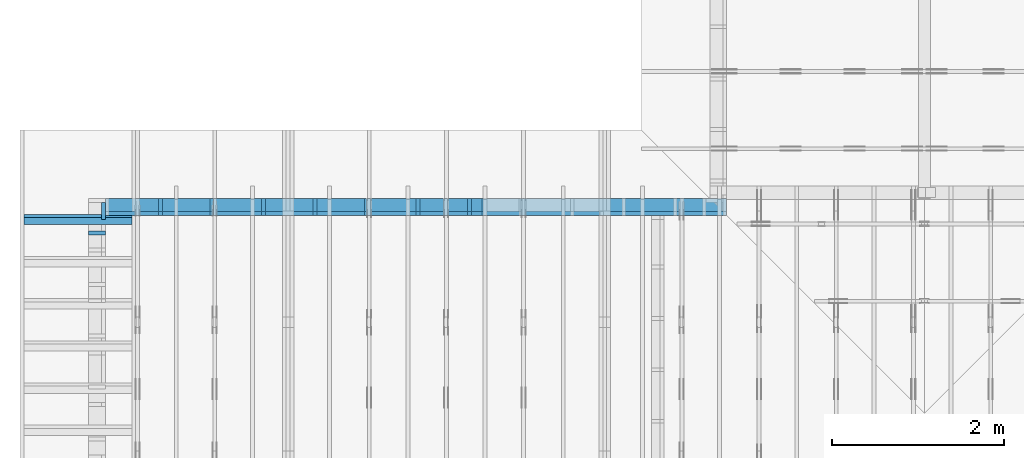
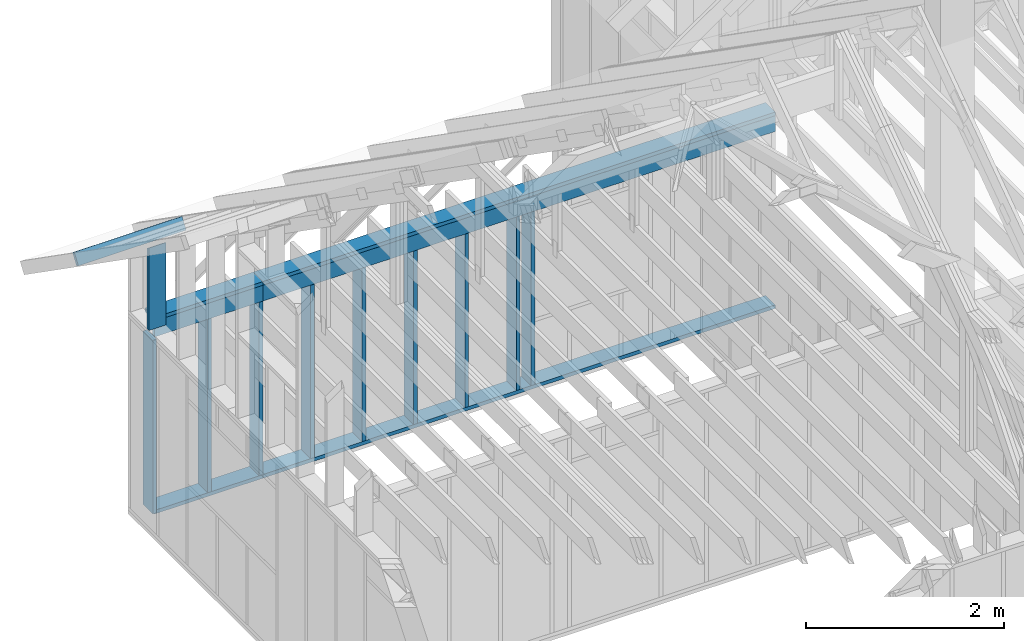
# One storey, part 29 of 70: 17 members, 4 elements without a shape of their own.
"""IFC2X3 building model written with IfcOpenShell, lengths in millimetres."""

from ifc_helpers import new_model, si_unit, frame, origin, origin_with_axes, origin_2d, place, context, project, spatial, faceted_brep, element, aggregate, save


model = new_model("IFC2X3")

# Units and contexts
model_context = context("Model", 3, precision=1e-05, world=origin())
plan_context = context("Plan", 2, precision=1e-05, world=origin_2d())
ifc_project = project(units=[si_unit("LENGTHUNIT", "METRE", prefix="MILLI"), si_unit("AREAUNIT", "SQUARE_METRE"), si_unit("VOLUMEUNIT", "CUBIC_METRE"), si_unit("SOLIDANGLEUNIT", "STERADIAN"), si_unit("PLANEANGLEUNIT", "RADIAN"), si_unit("MASSUNIT", "GRAM"), si_unit("TIMEUNIT", "SECOND"), si_unit("THERMODYNAMICTEMPERATUREUNIT", "DEGREE_CELSIUS"), si_unit("LUMINOUSINTENSITYUNIT", "LUMEN")], contexts=[model_context, plan_context])

# Site, building, storey
site_placement = place(None, origin_with_axes())
site = spatial("IfcSite", under=ifc_project, at=site_placement, CompositionType="ELEMENT")
building_placement = place(site_placement, origin_with_axes())
building = spatial("IfcBuilding", under=site, at=building_placement, Name="Layout 1", CompositionType="ELEMENT")
storey_placement = place(building_placement, origin_with_axes())
storey = spatial("IfcBuildingStorey", under=building, at=storey_placement, Name="Storey 1", CompositionType="ELEMENT", Elevation=0.0)

# Assembly, members
assembly_1_placement = place(storey_placement, frame((6999.999999999999, 8000.0, -2470.0), z_axis=(1.2246063538223773e-16, 1.0, 6.123031769111886e-17), x_axis=(-1.0, 1.2246063538223773e-16, 0.0)))
assembly_1 = element("IfcElementAssembly", 1, at=assembly_1_placement, inside=storey, Name="VE2", AssemblyPlace="FACTORY", PredefinedType="NOTDEFINED")
member_1_placement = place(assembly_1_placement, frame((-194.99999999999986, 2425.0, -195.0), z_axis=(0.0, 0.0, 1.0), x_axis=(1.0, 0.0, 0.0)))
member_1 = element("IfcMember", 2, at=member_1_placement, Name="P1", context=model_context, shape_type="Brep", body=[
    faceted_brep([(5980.0, 45.0, 195.0), (0.0, 45.0, 195.0), (0.0, 0.0, 195.0), (5980.0, 0.0, 195.0), (0.0, 45.0, 0.0), (5980.0, 45.0, 7.323145995857816e-13), (5980.0, 0.0, 7.323145995857816e-13), (0.0, 0.0, 0.0), (0.0, 0.0, 0.0), (1.1939911949768178e-14, -1.462169203776584e-30, 195.0), (1.7450640541968876e-14, 45.0, 195.0), (5.510728592200698e-15, 45.0, -3.3742366240998092e-31), (5980.0, -1.0984718993786724e-12, 6.725978337372286e-29), (5980.0, -1.0865319874289042e-12, 195.0), (2.193253805664876e-30, 1.1939911949768178e-14, 195.0), (0.0, 0.0, 0.0), (5980.0, 45.0, 0.0), (5980.0, 45.0, 195.0), (5980.0, 0.0, 195.0), (5980.0, 0.0, 0.0), (0.0, 45.0, 0.0), (-7.31084601888292e-31, 44.999999999999986, 195.0), (5980.0, 44.99999999999962, 195.0), (5980.0, 44.99999999999963, -2.2482535798798836e-29)], [[[0, 1, 2, 3]], [[4, 5, 6, 7]], [[8, 9, 10, 11]], [[12, 13, 14, 15]], [[16, 17, 18, 19]], [[20, 21, 22, 23]]]),
])
member_2_placement = place(assembly_1_placement, frame((5785.0, 2425.0, -195.0), z_axis=(0.0, 0.0, 1.0), x_axis=(1.0, 0.0, 0.0)))
member_2 = element("IfcMember", 3, at=member_2_placement, Name="P12", context=model_context, shape_type="Brep", body=[
    faceted_brep([(1263.5533905932753, 45.0, 195.0), (0.0, 45.0, 195.0), (0.0, 0.0, 195.0), (1263.5533905932753, 0.0, 195.0), (0.0, 45.0, 0.0), (1263.5533905932753, 45.0, 1.5473555105143328e-13), (1263.5533905932753, 0.0, 1.5473555105143328e-13), (0.0, 0.0, 0.0), (0.0, 0.0, 0.0), (1.1939911949768178e-14, -1.462169203776584e-30, 195.0), (1.7450640541968876e-14, 45.0, 195.0), (5.510728592200698e-15, 45.0, -3.3742366240998092e-31), (1263.5533905932753, -2.3210332657714993e-13, 1.4211760423484402e-29), (1263.5533905932753, -2.2016341462738176e-13, 195.0), (2.193253805664876e-30, 1.1939911949768178e-14, 195.0), (0.0, 0.0, 0.0), (1263.5533905932753, 45.0, 0.0), (1263.5533905932753, 45.0, 195.0), (1263.5533905932753, 0.0, 195.0), (1263.5533905932753, 0.0, 0.0), (0.0, 45.0, 0.0), (-7.31084601888292e-31, 44.999999999999986, 195.0), (1263.5533905932753, 44.99999999999991, 195.0), (1263.5533905932753, 44.99999999999992, -4.733165431326071e-30)], [[[0, 1, 2, 3]], [[4, 5, 6, 7]], [[8, 9, 10, 11]], [[12, 13, 14, 15]], [[16, 17, 18, 19]], [[20, 21, 22, 23]]]),
])
member_3_placement = place(assembly_1_placement, frame((7048.553390593275, 90.0, -195.0), z_axis=(0.0, 0.0, 1.0), x_axis=(-1.0, 1.2246063538223773e-16, 0.0)))
member_3 = element("IfcMember", 4, at=member_3_placement, Name="P12", context=model_context, shape_type="Brep", body=[
    faceted_brep([(1263.5533905932753, 45.000000000000156, 195.0), (0.0, 45.000000000000156, 195.0), (0.0, 0.0, 195.0), (1263.5533905932753, 0.0, 195.0), (0.0, 45.000000000000156, 0.0), (1263.5533905932753, 45.000000000000156, 1.5473555105143328e-13), (1263.5533905932753, 0.0, 1.5473555105143328e-13), (0.0, 0.0, 0.0), (0.0, 0.0, 0.0), (1.1939911949768178e-14, -1.462169203776584e-30, 195.0), (1.7450640541968876e-14, 45.00000000000001, 195.0), (5.5107285922006985e-15, 45.00000000000001, -3.3742366240998097e-31), (1263.5533905932753, -2.3210332657714993e-13, 2.3783247061100087e-29), (1263.5533905932753, -2.2016341462738176e-13, 195.0), (2.193253805664876e-30, 1.1939911949768178e-14, 195.0), (0.0, 0.0, 0.0), (1263.5533905932753, 45.000000000000156, 0.0), (1263.5533905932753, 45.000000000000156, 195.0), (1263.5533905932753, 1.5631940186722204e-13, 195.0), (1263.5533905932753, 1.5631940186722204e-13, 0.0), (0.0, 45.00000000000001, 0.0), (1.5777218104420236e-30, 44.99999999999999, 195.0), (1263.5533905932753, 45.0000000000002, 195.0), (1263.5533905932753, 45.00000000000021, 3.549874073494553e-30)], [[[0, 1, 2, 3]], [[4, 5, 6, 7]], [[8, 9, 10, 11]], [[12, 13, 14, 15]], [[16, 17, 18, 19]], [[20, 21, 22, 23]]]),
])
member_4_placement = place(assembly_1_placement, frame((5785.0, 90.0, -195.0), z_axis=(0.0, 0.0, 1.0), x_axis=(-1.0, 1.2246063538223773e-16, 0.0)))
member_4 = element("IfcMember", 5, at=member_4_placement, Name="P1", context=model_context, shape_type="Brep", body=[
    faceted_brep([(5980.0, 45.00000000000073, 195.0), (0.0, 45.00000000000073, 195.0), (0.0, 0.0, 195.0), (5980.0, 0.0, 195.0), (0.0, 45.00000000000073, 0.0), (5980.0, 45.00000000000073, 7.323145995857816e-13), (5980.0, 0.0, 7.323145995857816e-13), (0.0, 0.0, 0.0), (0.0, 0.0, 0.0), (1.1939911949768178e-14, -1.462169203776584e-30, 195.0), (1.7450640541968876e-14, 45.0, 195.0), (5.510728592200698e-15, 45.0, -3.3742366240998092e-31), (5980.0, -1.0984718993786724e-12, 1.1250681111517883e-28), (5980.0, -1.0865319874289042e-12, 195.0), (2.193253805664876e-30, 1.1939911949768178e-14, 195.0), (0.0, 0.0, 0.0), (5980.0, 45.00000000000073, 0.0), (5980.0, 45.00000000000073, 195.0), (5980.0, 7.389644451905042e-13, 195.0), (5980.0, 7.389644451905042e-13, 0.0), (0.0, 45.0, 0.0), (1.5777218104420236e-30, 44.999999999999986, 195.0), (5980.0, 45.00000000000095, 195.0), (5980.0, 45.00000000000096, 1.3805065841367707e-29)], [[[0, 1, 2, 3]], [[4, 5, 6, 7]], [[8, 9, 10, 11]], [[12, 13, 14, 15]], [[16, 17, 18, 19]], [[20, 21, 22, 23]]]),
])
member_5_placement = place(assembly_1_placement, frame((-194.99999999999986, 2229.9999999981374, -195.0), z_axis=(0.0, 0.0, 1.0), x_axis=(1.0, 0.0, 0.0)))
member_5 = element("IfcMember", 6, at=member_5_placement, Name="S34", context=model_context, shape_type="Brep", body=[
    faceted_brep([(5980.0, 195.00000000186265, 45.0), (0.0, 195.00000000186265, 45.0), (0.0, 0.0, 45.0), (5980.0, 0.0, 45.0), (0.0, 195.00000000186265, 0.0), (5980.0, 195.00000000186265, 7.323145995857816e-13), (5980.0, 0.0, 7.323145995857816e-13), (0.0, 0.0, 0.0), (0.0, 0.0, 0.0), (2.755364296100349e-15, -3.3742366240998092e-31, 45.0), (2.6635188195864806e-14, 195.00000000186265, 45.0), (2.3879823899764457e-14, 195.00000000186265, -1.4621692037905507e-30), (5980.0, 1.86317026748279e-09, -3.2153157385149134e-29), (5980.0, 1.8631730228470863e-09, 45.0), (-8.584804067855881e-28, 2.755364296100349e-15, 45.0), (0.0, 0.0, 0.0), (5980.0, 195.00000000186265, 0.0), (5980.0, 195.00000000186265, 45.0), (5980.0, 1.862645149230957e-09, 45.0), (5980.0, 1.862645149230957e-09, 0.0), (0.0, 195.00000000186265, 0.0), (-1.6871183120499046e-31, 195.00000000186265, 45.0), (5980.0, 195.00000000186228, 45.0), (5980.0, 195.00000000186228, -2.208810534618833e-29)], [[[0, 1, 2, 3]], [[4, 5, 6, 7]], [[8, 9, 10, 11]], [[12, 13, 14, 15]], [[16, 17, 18, 19]], [[20, 21, 22, 23]]]),
])
member_6_placement = place(assembly_1_placement, frame((5785.0, 2230.0, -195.0), z_axis=(0.0, 0.0, 1.0), x_axis=(1.0, 0.0, 0.0)))
member_6 = element("IfcMember", 7, at=member_6_placement, Name="L9", context=model_context, shape_type="Brep", body=[
    faceted_brep([(1263.5533905932753, 195.0, 45.0), (0.0, 195.0, 45.0), (0.0, 0.0, 45.0), (1263.5533905932753, 0.0, 45.0), (0.0, 195.0, 0.0), (1263.5533905932753, 195.0, 1.5473555105143328e-13), (1263.5533905932753, 0.0, 1.5473555105143328e-13), (0.0, 0.0, 0.0), (0.0, 0.0, 0.0), (2.755364296100349e-15, -3.3742366240998092e-31, 45.0), (2.6635188195636705e-14, 195.0, 45.0), (2.3879823899536357e-14, 195.0, -1.462169203776584e-30), (1263.5533905932753, -2.3210332657714993e-13, 1.4211760423484402e-29), (1263.5533905932753, -2.293479622810496e-13, 45.0), (5.061354936149714e-31, 2.755364296100349e-15, 45.0), (0.0, 0.0, 0.0), (1263.5533905932753, 195.0, 0.0), (1263.5533905932753, 195.0, 45.0), (1263.5533905932753, 0.0, 45.0), (1263.5533905932753, 0.0, 0.0), (0.0, 195.0, 0.0), (-1.6871183120499046e-31, 195.0, 45.0), (1263.5533905932753, 194.99999999999991, 45.0), (1263.5533905932753, 194.99999999999991, -4.733165431326071e-30)], [[[0, 1, 2, 3]], [[4, 5, 6, 7]], [[8, 9, 10, 11]], [[12, 13, 14, 15]], [[16, 17, 18, 19]], [[20, 21, 22, 23]]]),
])
member_7_placement = place(assembly_1_placement, frame((5182.500000001819, 2425.0, -195.00000000000003), z_axis=(0.0, 0.0, 1.0), x_axis=(-1.836909530733566e-16, -1.0, 0.0)))
member_7 = element("IfcMember", 8, at=member_7_placement, Name="S11", context=model_context, shape_type="Brep", body=[
    faceted_brep([(0.0, 45.00000000001455, 45.00000000000003), (195.00000000186265, 45.00000000001455, 45.00000000000005), (195.00000000186265, 0.0, 45.00000000000005), (0.0, 0.0, 45.00000000000003), (195.00000000186265, -2.1311460639909362e-46, 2.842170943040401e-14), (195.00000000186265, -3.3742366240998114e-31, 45.00000000000003), (195.00000000186265, 45.00000000001364, 45.00000000000003), (195.00000000186265, 45.00000000001364, 2.842170943040401e-14), (2.7553642961003504e-15, -3.3742366240998114e-31, 45.00000000000003), (1.1939911949768181e-14, -1.4621692037765844e-30, 195.00000000000006), (1.7450640541970662e-14, 45.00000000001455, 195.00000000000006), (8.26609288830283e-15, 45.00000000001455, 45.00000000000003), (2335.0, -4.2891837542628763e-13, 2.842170943040403e-14), (2335.0, -4.1697846347651946e-13, 195.00000000000003), (2.1932538056648764e-30, 1.193991194976818e-14, 195.00000000000003), (5.061354936149717e-31, 2.7553642961003504e-15, 45.00000000000003), (195.00000000186265, -3.306437155354634e-14, 45.00000000000003), (195.00000000186265, -3.5819735849646686e-14, 2.842170943040401e-14), (-1.6871183120499057e-31, 45.00000000001364, 45.00000000000003), (-7.310846018882921e-31, 45.00000000001363, 195.00000000000003), (2335.0, 45.000000000013486, 195.00000000000003), (2335.0, 45.0000000000135, 2.8421709430403998e-14), (195.00000000186265, 45.00000000001363, 2.842170943040401e-14), (195.00000000186265, 45.00000000001363, 45.00000000000003), (2335.0, 45.0, 0.0), (2335.0, 45.0, 195.00000000000003), (2335.0, 0.0, 195.00000000000003), (2335.0, 0.0, 0.0), (2335.0, 45.0, 195.00000000000003), (0.0, 45.0, 195.00000000000003), (0.0, 0.0, 195.00000000000003), (2335.0, 0.0, 195.00000000000003), (195.00000000186265, 45.00000000001364, 5.2301533330168465e-14), (2335.0, 45.00000000001364, 3.143672930479291e-13), (2335.0, 0.0, 3.143672930479291e-13), (195.00000000186265, 0.0, 5.2301533330168465e-14)], [[[0, 1, 2, 3]], [[4, 5, 6, 7]], [[8, 9, 10, 11]], [[12, 13, 14, 15, 16, 17]], [[18, 19, 20, 21, 22, 23]], [[24, 25, 26, 27]], [[28, 29, 30, 31]], [[32, 33, 34, 35]]]),
])
member_8_placement = place(assembly_1_placement, frame((5782.500000001819, 2425.0, -195.00000000000003), z_axis=(0.0, 0.0, 1.0), x_axis=(-1.836909530733566e-16, -1.0, 0.0)))
member_8 = element("IfcMember", 9, at=member_8_placement, Name="S11", context=model_context, shape_type="Brep", body=[
    faceted_brep([(0.0, 45.00000000001455, 45.00000000000003), (195.00000000186265, 45.00000000001455, 45.00000000000005), (195.00000000186265, 0.0, 45.00000000000005), (0.0, 0.0, 45.00000000000003), (195.00000000186265, -2.1311460639909362e-46, 2.842170943040401e-14), (195.00000000186265, -3.3742366240998114e-31, 45.00000000000003), (195.00000000186265, 45.00000000001364, 45.00000000000003), (195.00000000186265, 45.00000000001364, 2.842170943040401e-14), (2.7553642961003504e-15, -3.3742366240998114e-31, 45.00000000000003), (1.1939911949768181e-14, -1.4621692037765844e-30, 195.00000000000006), (1.7450640541970662e-14, 45.00000000001455, 195.00000000000006), (8.26609288830283e-15, 45.00000000001455, 45.00000000000003), (2335.0, -4.2891837542628763e-13, 2.842170943040403e-14), (2335.0, -4.1697846347651946e-13, 195.00000000000003), (2.1932538056648764e-30, 1.193991194976818e-14, 195.00000000000003), (5.061354936149717e-31, 2.7553642961003504e-15, 45.00000000000003), (195.00000000186265, -3.306437155354634e-14, 45.00000000000003), (195.00000000186265, -3.5819735849646686e-14, 2.842170943040401e-14), (-1.6871183120499057e-31, 45.00000000001364, 45.00000000000003), (-7.310846018882921e-31, 45.00000000001363, 195.00000000000003), (2335.0, 45.000000000013486, 195.00000000000003), (2335.0, 45.0000000000135, 2.8421709430403998e-14), (195.00000000186265, 45.00000000001363, 2.842170943040401e-14), (195.00000000186265, 45.00000000001363, 45.00000000000003), (2335.0, 45.0, 0.0), (2335.0, 45.0, 195.00000000000003), (2335.0, 0.0, 195.00000000000003), (2335.0, 0.0, 0.0), (2335.0, 45.0, 195.00000000000003), (0.0, 45.0, 195.00000000000003), (0.0, 0.0, 195.00000000000003), (2335.0, 0.0, 195.00000000000003), (195.00000000186265, 45.00000000001364, 5.2301533330168465e-14), (2335.0, 45.00000000001364, 3.143672930479291e-13), (2335.0, 0.0, 3.143672930479291e-13), (195.00000000186265, 0.0, 5.2301533330168465e-14)], [[[0, 1, 2, 3]], [[4, 5, 6, 7]], [[8, 9, 10, 11]], [[12, 13, 14, 15, 16, 17]], [[18, 19, 20, 21, 22, 23]], [[24, 25, 26, 27]], [[28, 29, 30, 31]], [[32, 33, 34, 35]]]),
])
member_9_placement = place(assembly_1_placement, frame((6382.500000001819, 2425.0, -195.00000000000003), z_axis=(0.0, 0.0, 1.0), x_axis=(-1.836909530733566e-16, -1.0, 0.0)))
member_9 = element("IfcMember", 10, at=member_9_placement, Name="S11", context=model_context, shape_type="Brep", body=[
    faceted_brep([(0.0, 45.00000000001455, 45.00000000000003), (195.00000000186265, 45.00000000001455, 45.00000000000005), (195.00000000186265, 0.0, 45.00000000000005), (0.0, 0.0, 45.00000000000003), (195.00000000186265, -2.1311460639909362e-46, 2.842170943040401e-14), (195.00000000186265, -3.3742366240998114e-31, 45.00000000000003), (195.00000000186265, 45.00000000001364, 45.00000000000003), (195.00000000186265, 45.00000000001364, 2.842170943040401e-14), (2.7553642961003504e-15, -3.3742366240998114e-31, 45.00000000000003), (1.1939911949768181e-14, -1.4621692037765844e-30, 195.00000000000006), (1.7450640541970662e-14, 45.00000000001455, 195.00000000000006), (8.26609288830283e-15, 45.00000000001455, 45.00000000000003), (2335.0, -4.2891837542628763e-13, 2.842170943040403e-14), (2335.0, -4.1697846347651946e-13, 195.00000000000003), (2.1932538056648764e-30, 1.193991194976818e-14, 195.00000000000003), (5.061354936149717e-31, 2.7553642961003504e-15, 45.00000000000003), (195.00000000186265, -3.306437155354634e-14, 45.00000000000003), (195.00000000186265, -3.5819735849646686e-14, 2.842170943040401e-14), (-1.6871183120499057e-31, 45.00000000001364, 45.00000000000003), (-7.310846018882921e-31, 45.00000000001363, 195.00000000000003), (2335.0, 45.000000000013486, 195.00000000000003), (2335.0, 45.0000000000135, 2.8421709430403998e-14), (195.00000000186265, 45.00000000001363, 2.842170943040401e-14), (195.00000000186265, 45.00000000001363, 45.00000000000003), (2335.0, 45.0, 0.0), (2335.0, 45.0, 195.00000000000003), (2335.0, 0.0, 195.00000000000003), (2335.0, 0.0, 0.0), (2335.0, 45.0, 195.00000000000003), (0.0, 45.0, 195.00000000000003), (0.0, 0.0, 195.00000000000003), (2335.0, 0.0, 195.00000000000003), (195.00000000186265, 45.00000000001364, 5.2301533330168465e-14), (2335.0, 45.00000000001364, 3.143672930479291e-13), (2335.0, 0.0, 3.143672930479291e-13), (195.00000000186265, 0.0, 5.2301533330168465e-14)], [[[0, 1, 2, 3]], [[4, 5, 6, 7]], [[8, 9, 10, 11]], [[12, 13, 14, 15, 16, 17]], [[18, 19, 20, 21, 22, 23]], [[24, 25, 26, 27]], [[28, 29, 30, 31]], [[32, 33, 34, 35]]]),
])
member_10_placement = place(assembly_1_placement, frame((4582.500000001819, 2425.0, -195.00000000000003), z_axis=(0.0, 0.0, 1.0), x_axis=(-1.836909530733566e-16, -1.0, 0.0)))
member_10 = element("IfcMember", 11, at=member_10_placement, Name="S11", context=model_context, shape_type="Brep", body=[
    faceted_brep([(0.0, 45.00000000001455, 45.00000000000003), (195.00000000186265, 45.00000000001455, 45.00000000000005), (195.00000000186265, 0.0, 45.00000000000005), (0.0, 0.0, 45.00000000000003), (195.00000000186265, -2.1311460639909362e-46, 2.842170943040401e-14), (195.00000000186265, -3.3742366240998114e-31, 45.00000000000003), (195.00000000186265, 45.00000000001364, 45.00000000000003), (195.00000000186265, 45.00000000001364, 2.842170943040401e-14), (2.7553642961003504e-15, -3.3742366240998114e-31, 45.00000000000003), (1.1939911949768181e-14, -1.4621692037765844e-30, 195.00000000000006), (1.7450640541970662e-14, 45.00000000001455, 195.00000000000006), (8.26609288830283e-15, 45.00000000001455, 45.00000000000003), (2335.0, -4.2891837542628763e-13, 2.842170943040403e-14), (2335.0, -4.1697846347651946e-13, 195.00000000000003), (2.1932538056648764e-30, 1.193991194976818e-14, 195.00000000000003), (5.061354936149717e-31, 2.7553642961003504e-15, 45.00000000000003), (195.00000000186265, -3.306437155354634e-14, 45.00000000000003), (195.00000000186265, -3.5819735849646686e-14, 2.842170943040401e-14), (-1.6871183120499057e-31, 45.00000000001364, 45.00000000000003), (-7.310846018882921e-31, 45.00000000001363, 195.00000000000003), (2335.0, 45.000000000013486, 195.00000000000003), (2335.0, 45.0000000000135, 2.8421709430403998e-14), (195.00000000186265, 45.00000000001363, 2.842170943040401e-14), (195.00000000186265, 45.00000000001363, 45.00000000000003), (2335.0, 45.0, 0.0), (2335.0, 45.0, 195.00000000000003), (2335.0, 0.0, 195.00000000000003), (2335.0, 0.0, 0.0), (2335.0, 45.0, 195.00000000000003), (0.0, 45.0, 195.00000000000003), (0.0, 0.0, 195.00000000000003), (2335.0, 0.0, 195.00000000000003), (195.00000000186265, 45.00000000001364, 5.2301533330168465e-14), (2335.0, 45.00000000001364, 3.143672930479291e-13), (2335.0, 0.0, 3.143672930479291e-13), (195.00000000186265, 0.0, 5.2301533330168465e-14)], [[[0, 1, 2, 3]], [[4, 5, 6, 7]], [[8, 9, 10, 11]], [[12, 13, 14, 15, 16, 17]], [[18, 19, 20, 21, 22, 23]], [[24, 25, 26, 27]], [[28, 29, 30, 31]], [[32, 33, 34, 35]]]),
])
member_11_placement = place(assembly_1_placement, frame((2782.500000001819, 2425.0, -195.0), z_axis=(0.0, 0.0, 1.0), x_axis=(-1.836909530733566e-16, -1.0, 0.0)))
member_11 = element("IfcMember", 12, at=member_11_placement, Name="S11", context=model_context, shape_type="Brep", body=[
    faceted_brep([(0.0, 45.00000000001455, 45.0), (195.00000000186265, 45.00000000001455, 45.00000000000002), (195.00000000186265, 0.0, 45.00000000000002), (0.0, 0.0, 45.0), (195.00000000186265, 0.0, 0.0), (195.00000000186265, -3.3742366240998092e-31, 45.0), (195.00000000186265, 45.00000000001455, 45.0), (195.00000000186265, 45.00000000001455, 0.0), (2.755364296100349e-15, -3.3742366240998092e-31, 45.0), (1.193991194976818e-14, -1.4621692037765842e-30, 195.00000000000003), (1.745064054197066e-14, 45.00000000001455, 195.00000000000003), (8.26609288830283e-15, 45.00000000001455, 45.0), (2335.0, -4.2891837542628763e-13, 2.626280839091018e-29), (2335.0, -4.1697846347651946e-13, 195.0), (2.193253805664876e-30, 1.1939911949768178e-14, 195.0), (5.061354936149714e-31, 2.755364296100349e-15, 45.0), (195.00000000186265, -3.306437155354634e-14, 45.0), (195.00000000186265, -3.5819735849646686e-14, 2.193253805685826e-30), (-1.6871183120499046e-31, 45.00000000001455, 45.0), (-7.31084601888292e-31, 45.00000000001454, 195.0), (2335.0, 45.000000000014396, 195.0), (2335.0, 45.00000000001441, -8.67746995743113e-30), (195.00000000186265, 45.00000000001454, -7.888609052210118e-31), (195.00000000186265, 45.00000000001454, 45.0), (2335.0, 45.00000000001501, 0.0), (2335.0, 45.00000000001501, 195.0), (2335.0, 4.547473508864641e-13, 195.0), (2335.0, 4.547473508864641e-13, 0.0), (2335.0, 45.00000000001501, 195.0), (0.0, 45.00000000001501, 195.0), (0.0, 0.0, 195.0), (2335.0, 0.0, 195.0), (195.00000000186265, 45.00000000001455, 2.3879823899764457e-14), (2335.0, 45.00000000001455, 2.859455836175251e-13), (2335.0, 4.547473508864641e-13, 2.859455836175251e-13), (195.00000000186265, 4.547473508864641e-13, 2.3879823899764457e-14)], [[[0, 1, 2, 3]], [[4, 5, 6, 7]], [[8, 9, 10, 11]], [[12, 13, 14, 15, 16, 17]], [[18, 19, 20, 21, 22, 23]], [[24, 25, 26, 27]], [[28, 29, 30, 31]], [[32, 33, 34, 35]]]),
])
member_12_placement = place(assembly_1_placement, frame((3382.500000001819, 2425.0, -195.00000000000003), z_axis=(0.0, 0.0, 1.0), x_axis=(-1.836909530733566e-16, -1.0, 0.0)))
member_12 = element("IfcMember", 13, at=member_12_placement, Name="S11", context=model_context, shape_type="Brep", body=[
    faceted_brep([(0.0, 45.00000000001455, 45.00000000000003), (195.00000000186265, 45.00000000001455, 45.00000000000005), (195.00000000186265, 0.0, 45.00000000000005), (0.0, 0.0, 45.00000000000003), (195.00000000186265, -2.1311460639909362e-46, 2.842170943040401e-14), (195.00000000186265, -3.3742366240998114e-31, 45.00000000000003), (195.00000000186265, 45.00000000001319, 45.00000000000003), (195.00000000186265, 45.00000000001319, 2.842170943040401e-14), (2.7553642961003504e-15, -3.3742366240998114e-31, 45.00000000000003), (1.1939911949768181e-14, -1.4621692037765844e-30, 195.00000000000006), (1.7450640541970662e-14, 45.00000000001455, 195.00000000000006), (8.26609288830283e-15, 45.00000000001455, 45.00000000000003), (2335.0, -4.2891837542628763e-13, 2.842170943040403e-14), (2335.0, -4.1697846347651946e-13, 195.00000000000003), (2.1932538056648764e-30, 1.193991194976818e-14, 195.00000000000003), (5.061354936149717e-31, 2.7553642961003504e-15, 45.00000000000003), (195.00000000186265, -3.306437155354634e-14, 45.00000000000003), (195.00000000186265, -3.5819735849646686e-14, 2.842170943040401e-14), (-1.6871183120499057e-31, 45.00000000001319, 45.00000000000003), (-7.310846018882921e-31, 45.00000000001317, 195.00000000000003), (2335.0, 45.00000000001303, 195.00000000000003), (2335.0, 45.000000000013046, 2.8421709430403998e-14), (195.00000000186265, 45.00000000001317, 2.842170943040401e-14), (195.00000000186265, 45.00000000001317, 45.00000000000003), (2335.0, 45.000000000000455, 0.0), (2335.0, 45.000000000000455, 195.00000000000003), (2335.0, 4.547473508864641e-13, 195.00000000000003), (2335.0, 4.547473508864641e-13, 0.0), (2335.0, 45.000000000000455, 195.00000000000003), (0.0, 45.000000000000455, 195.00000000000003), (0.0, 0.0, 195.00000000000003), (2335.0, 0.0, 195.00000000000003), (195.00000000186265, 45.00000000001319, 5.2301533330168465e-14), (2335.0, 45.00000000001319, 3.143672930479291e-13), (2335.0, 4.547473508864641e-13, 3.143672930479291e-13), (195.00000000186265, 4.547473508864641e-13, 5.2301533330168465e-14)], [[[0, 1, 2, 3]], [[4, 5, 6, 7]], [[8, 9, 10, 11]], [[12, 13, 14, 15, 16, 17]], [[18, 19, 20, 21, 22, 23]], [[24, 25, 26, 27]], [[28, 29, 30, 31]], [[32, 33, 34, 35]]]),
])
member_13_placement = place(assembly_1_placement, frame((3982.500000001819, 2425.0, -195.00000000000003), z_axis=(0.0, 0.0, 1.0), x_axis=(-1.836909530733566e-16, -1.0, 0.0)))
member_13 = element("IfcMember", 14, at=member_13_placement, Name="S11", context=model_context, shape_type="Brep", body=[
    faceted_brep([(0.0, 45.00000000001455, 45.00000000000003), (195.00000000186265, 45.00000000001455, 45.00000000000005), (195.00000000186265, 0.0, 45.00000000000005), (0.0, 0.0, 45.00000000000003), (195.00000000186265, -2.1311460639909362e-46, 2.842170943040401e-14), (195.00000000186265, -3.3742366240998114e-31, 45.00000000000003), (195.00000000186265, 45.00000000001319, 45.00000000000003), (195.00000000186265, 45.00000000001319, 2.842170943040401e-14), (2.7553642961003504e-15, -3.3742366240998114e-31, 45.00000000000003), (1.1939911949768181e-14, -1.4621692037765844e-30, 195.00000000000006), (1.7450640541970662e-14, 45.00000000001455, 195.00000000000006), (8.26609288830283e-15, 45.00000000001455, 45.00000000000003), (2335.0, -4.2891837542628763e-13, 2.842170943040403e-14), (2335.0, -4.1697846347651946e-13, 195.00000000000003), (2.1932538056648764e-30, 1.193991194976818e-14, 195.00000000000003), (5.061354936149717e-31, 2.7553642961003504e-15, 45.00000000000003), (195.00000000186265, -3.306437155354634e-14, 45.00000000000003), (195.00000000186265, -3.5819735849646686e-14, 2.842170943040401e-14), (-1.6871183120499057e-31, 45.00000000001319, 45.00000000000003), (-7.310846018882921e-31, 45.00000000001317, 195.00000000000003), (2335.0, 45.00000000001303, 195.00000000000003), (2335.0, 45.000000000013046, 2.8421709430403998e-14), (195.00000000186265, 45.00000000001317, 2.842170943040401e-14), (195.00000000186265, 45.00000000001317, 45.00000000000003), (2335.0, 45.000000000000455, 0.0), (2335.0, 45.000000000000455, 195.00000000000003), (2335.0, 4.547473508864641e-13, 195.00000000000003), (2335.0, 4.547473508864641e-13, 0.0), (2335.0, 45.000000000000455, 195.00000000000003), (0.0, 45.000000000000455, 195.00000000000003), (0.0, 0.0, 195.00000000000003), (2335.0, 0.0, 195.00000000000003), (195.00000000186265, 45.00000000001319, 5.2301533330168465e-14), (2335.0, 45.00000000001319, 3.143672930479291e-13), (2335.0, 4.547473508864641e-13, 3.143672930479291e-13), (195.00000000186265, 4.547473508864641e-13, 5.2301533330168465e-14)], [[[0, 1, 2, 3]], [[4, 5, 6, 7]], [[8, 9, 10, 11]], [[12, 13, 14, 15, 16, 17]], [[18, 19, 20, 21, 22, 23]], [[24, 25, 26, 27]], [[28, 29, 30, 31]], [[32, 33, 34, 35]]]),
])
member_14_placement = place(assembly_1_placement, frame((2610.000000001819, 2425.0, -195.0), z_axis=(0.0, 0.0, 1.0), x_axis=(-1.836909530733566e-16, -1.0, 0.0)))
member_14 = element("IfcMember", 15, at=member_14_placement, Name="S11", context=model_context, shape_type="Brep", body=[
    faceted_brep([(0.0, 45.0, 45.0), (195.00000000186265, 45.0, 45.00000000000002), (195.00000000186265, 0.0, 45.00000000000002), (0.0, 0.0, 45.0), (195.00000000186265, 0.0, 0.0), (195.00000000186265, -3.3742366240998092e-31, 45.0), (195.00000000186265, 45.000000000001364, 45.0), (195.00000000186265, 45.000000000001364, 0.0), (2.755364296100349e-15, -3.3742366240998092e-31, 45.0), (1.1939911949768178e-14, -1.462169203776584e-30, 195.0), (1.7450640541968876e-14, 45.0, 195.0), (8.266092888301046e-15, 45.0, 45.0), (2335.0, -4.2891837542628763e-13, 2.626280839091018e-29), (2335.0, -4.1697846347651946e-13, 195.0), (2.193253805664876e-30, 1.1939911949768178e-14, 195.0), (5.061354936149714e-31, 2.755364296100349e-15, 45.0), (195.00000000186265, -3.306437155354634e-14, 45.0), (195.00000000186265, -3.5819735849646686e-14, 2.193253805685826e-30), (-1.6871183120499046e-31, 45.000000000001364, 45.0), (-7.31084601888292e-31, 45.00000000000135, 195.0), (2335.0, 45.00000000000121, 195.0), (2335.0, 45.00000000000122, -8.67746995743113e-30), (195.00000000186265, 45.00000000000135, -7.888609052210118e-31), (195.00000000186265, 45.00000000000135, 45.0), (2335.0, 45.00000000001501, 0.0), (2335.0, 45.00000000001501, 195.0), (2335.0, 4.547473508864641e-13, 195.0), (2335.0, 4.547473508864641e-13, 0.0), (2335.0, 45.00000000001501, 195.0), (0.0, 45.00000000001501, 195.0), (0.0, 0.0, 195.0), (2335.0, 0.0, 195.0), (195.00000000186265, 45.000000000001364, 2.3879823899764457e-14), (2335.0, 45.000000000001364, 2.859455836175251e-13), (2335.0, 4.547473508864641e-13, 2.859455836175251e-13), (195.00000000186265, 4.547473508864641e-13, 2.3879823899764457e-14)], [[[0, 1, 2, 3]], [[4, 5, 6, 7]], [[8, 9, 10, 11]], [[12, 13, 14, 15, 16, 17]], [[18, 19, 20, 21, 22, 23]], [[24, 25, 26, 27]], [[28, 29, 30, 31]], [[32, 33, 34, 35]]]),
])
aggregate(assembly_1, [member_1, member_2, member_3, member_4, member_5, member_6, member_7, member_8, member_9, member_10, member_11, member_12, member_13, member_14])

# Assembly, member
assembly_2_placement = place(storey_placement, frame((-243.55339059327574, 8000.000000000001, -2470.0), z_axis=(-1.0, 1.836909530733566e-16, 6.123031769111886e-17), x_axis=(-1.836909530733566e-16, -1.0, 0.0)))
assembly_2 = element("IfcElementAssembly", 16, at=assembly_2_placement, inside=storey, Name="VE3", AssemblyPlace="FACTORY", PredefinedType="NOTDEFINED")
member_15_placement = place(assembly_2_placement, frame((240.0, 89.99999999999999, -195.0), z_axis=(0.0, 0.0, 1.0), x_axis=(6.123031769111886e-17, 1.0, 0.0)))
member_15 = element("IfcMember", 17, at=member_15_placement, Name="S49", context=model_context, shape_type="Brep", body=[
    faceted_brep([(2140.0, 195.00000000000014, 45.0), (0.0, 195.00000000000014, 45.0), (1.4210854715202004e-14, 0.0, 45.0), (2140.0, 0.0, 45.0), (0.0, 195.00000000000014, 0.0), (2140.0, 195.00000000000014, 2.6206575971798873e-13), (2140.0, 0.0, 2.6206575971798873e-13), (1.4210854715202004e-14, 0.0, 1.7402702977483063e-30), (1.4210854715202004e-14, 0.0, 0.0), (1.6966219011302353e-14, -3.3742366240998092e-31, 45.0), (4.084604291083871e-14, 195.0, 45.0), (3.809067861473836e-14, 195.0, -2.332304352650737e-30), (2140.0, -3.930986395769831e-13, 3.277090607398684e-29), (2140.0, -3.9034327528088275e-13, 45.0), (1.4210854715202004e-14, 2.7553642961003453e-15, 45.0), (1.4210854715202004e-14, -3.5540895201578756e-30, 2.176180304219429e-46), (2140.0, 195.00000000000014, 0.0), (2140.0, 195.00000000000014, 45.0), (2140.0, 1.4210854715202004e-13, 45.0), (2140.0, 1.4210854715202004e-13, 0.0), (0.0, 195.0, 0.0), (0.0, 195.0, 45.0), (2140.0, 195.00000000000034, 45.0), (2140.0, 195.00000000000034, 1.1044052673094165e-29)], [[[0, 1, 2, 3]], [[4, 5, 6, 7]], [[8, 9, 10, 11]], [[12, 13, 14, 15]], [[16, 17, 18, 19]], [[20, 21, 22, 23]]]),
])
aggregate(assembly_2, [member_15])

assembly_3_placement = place(storey_placement, frame((-48.55339059327645, 2.2546681725408788e-11, 1.1939911949768178e-14), z_axis=(1.0, 1.156240088482502e-13, 6.123031769111886e-17), x_axis=(-1.156240088482502e-13, 1.0, 0.0)))
assembly_3 = element("IfcElementAssembly", 18, at=assembly_3_placement, inside=storey, Name="VEg1", AssemblyPlace="FACTORY", PredefinedType="NOTDEFINED")
member_16_placement = place(assembly_3_placement, frame((7622.500000010478, 45.0, -195.0), z_axis=(0.0, 0.0, 1.0), x_axis=(-1.0489927069340377e-15, 1.0, 0.0)))
member_16 = element("IfcMember", 19, at=member_16_placement, Name="S30", context=model_context, shape_type="Brep", body=[
    faceted_brep([(1018.8905130212879, 44.99999999998545, 195.0), (4.263256414560601e-14, 44.99999999998545, 195.0), (0.0, 9.094947017729282e-13, 195.0), (987.3811738018485, 9.094947017729282e-13, 195.0), (4.263256414560601e-14, 44.99999999998545, 5.220810893244919e-30), (1018.8905130212879, 44.99999999998545, 1.2477397960952107e-13), (987.3811738018485, 9.094947017729282e-13, 1.2091532590823407e-13), (0.0, 9.094947017729282e-13, 0.0), (6.089020112174685e-29, 9.094947017729282e-13, -3.728326358960682e-45), (1.193991194976824e-14, 9.094947017729282e-13, 195.0), (5.741866942847457e-14, 45.00000000000091, 195.0), (4.5478757478706396e-14, 45.00000000000091, -1.7427332199608106e-31), (987.3811738018485, -1.4884893767840334e-13, 9.114067742034188e-30), (987.3811738018485, -1.3690902572863516e-13, 195.0), (1.2798025932568618e-29, 9.214346137226964e-13, 195.0), (0.0, 9.094947017729282e-13, 0.0), (1018.8905130212878, 44.99999999998556, -1.262177448353619e-29), (1018.8905130212878, 44.99999999998556, 195.0), (987.3811738018485, 1.7053025658242404e-13, 195.0), (987.3811738018485, 1.7053025658242404e-13, -6.310887241768095e-30), (4.263256414560601e-14, 45.00000000000091, 0.0), (4.263256414560581e-14, 45.000000000000895, 195.0), (1018.8905130212879, 44.99999999998545, 195.0), (1018.8905130212879, 44.99999999998546, 7.888609052210118e-31)], [[[0, 1, 2, 3]], [[4, 5, 6, 7]], [[8, 9, 10, 11]], [[12, 13, 14, 15]], [[16, 17, 18, 19]], [[20, 21, 22, 23]]]),
])
aggregate(assembly_3, [member_16])

assembly_4_placement = place(storey_placement, frame((-1043.5533905932762, 8800.000000000002, 439.83396943223045), z_axis=(9.428742447176872e-17, 0.5735764363510464, 0.8191520442889916), x_axis=(-1.153505523095189e-16, -0.8191520442889916, 0.5735764363510464)))
assembly_4 = element("IfcElementAssembly", 20, at=assembly_4_placement, inside=storey, Name="gs1", AssemblyPlace="FACTORY", PredefinedType="TRUSS")
member_17_placement = place(assembly_4_placement, frame((1244.999999998996, 44.99999999999999, -145.0), z_axis=(0.0, 0.0, 1.0), x_axis=(6.123031769111886e-17, 1.0, 0.0)))
member_17 = element("IfcMember", 21, at=member_17_placement, Name="W4", context=model_context, shape_type="Brep", body=[
    faceted_brep([(1258.5533905932764, 45.00000000001455, 145.0), (0.0, 45.00000000001455, 145.0), (7.105427357601002e-15, 0.0, 145.0), (1258.5533905932764, 0.0, 145.0), (0.0, 45.00000000001455, 0.0), (1258.5533905932764, 45.00000000001455, 1.5412324787452224e-13), (1258.5533905932764, 0.0, 1.5412324787452224e-13), (7.105427357601002e-15, 0.0, 8.701351488741532e-31), (7.105427357601002e-15, 0.0, 0.0), (1.5983823422813237e-14, -1.0872540233210496e-30, 145.0), (2.1494552015015717e-14, 45.00000000001455, 145.0), (1.2616155949803482e-14, 45.00000000001455, -7.724912368471666e-31), (1258.5533905932764, 1.5418294590103406e-11, -5.3048683560158e-29), (1258.5533905932764, 1.5427172986168618e-11, 145.0), (7.105427357600893e-15, 8.87839606521224e-15, 145.0), (7.105427357601002e-15, 4.891326553927039e-30, -2.994974788279585e-46), (1258.5533905932764, 45.00000000001455, 0.0), (1258.5533905932764, 45.00000000001455, 145.0), (1258.5533905932764, 1.4551915228366852e-11, 145.0), (1258.5533905932764, 1.4551915228366852e-11, 0.0), (-1.2154326714572542e-63, 45.00000000001455, 0.0), (-5.436270116605248e-31, 45.000000000014545, 145.0), (1258.5533905932764, 45.00000000001447, 145.0), (1258.5533905932764, 45.000000000014474, -4.733165431326071e-30)], [[[0, 1, 2, 3]], [[4, 5, 6, 7]], [[8, 9, 10, 11]], [[12, 13, 14, 15]], [[16, 17, 18, 19]], [[20, 21, 22, 23]]]),
])
aggregate(assembly_4, [member_17])

save(model, "model.ifc")
